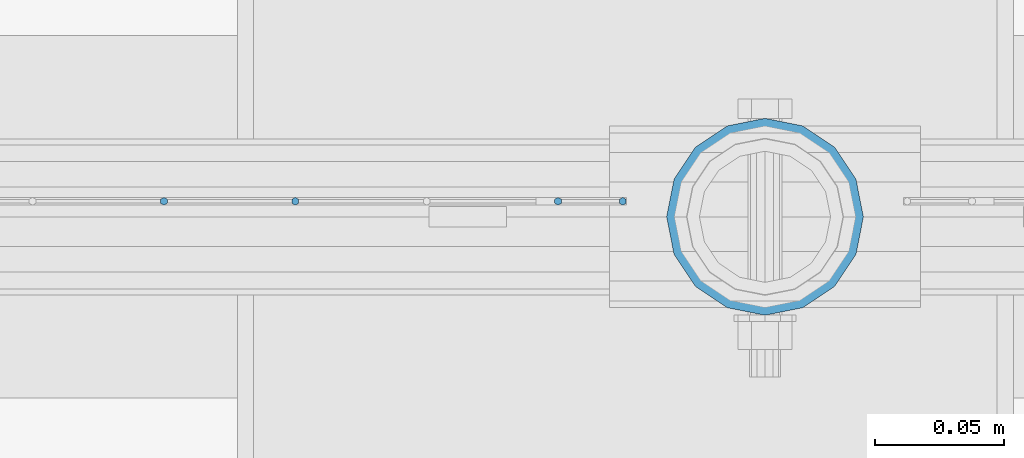
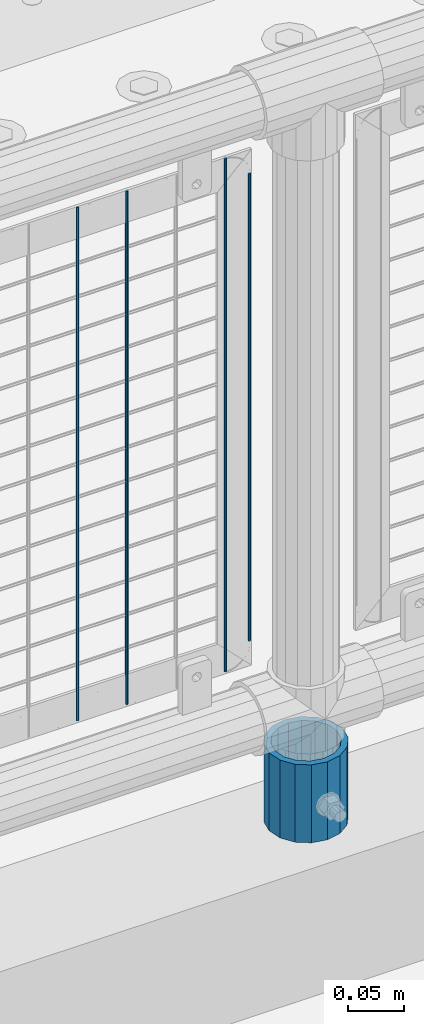
# One storey, part 66 of 242: 5 columns.
"""IFC2X3 building model written with IfcOpenShell, lengths in millimetres."""

from ifc_helpers import new_model, si_unit, frame, origin_with_axes, place, context, subcontext, project, spatial, faceted_brep, material, type_object, element, save


model = new_model("IFC2X3")

# Units and contexts
model_context = context("Model", 3, precision=1e-05, world=origin_with_axes())
body_context = subcontext(model_context, "Body", "Model", "MODEL_VIEW")
ifc_project = project(units=[si_unit("LENGTHUNIT", "METRE", prefix="MILLI"), si_unit("AREAUNIT", "SQUARE_METRE"), si_unit("VOLUMEUNIT", "CUBIC_METRE"), si_unit("MASSUNIT", "GRAM", prefix="KILO"), si_unit("TIMEUNIT", "SECOND"), si_unit("PLANEANGLEUNIT", "RADIAN"), si_unit("SOLIDANGLEUNIT", "STERADIAN"), si_unit("THERMODYNAMICTEMPERATUREUNIT", "DEGREE_CELSIUS"), si_unit("LUMINOUSINTENSITYUNIT", "LUMEN")], contexts=[model_context])

# Site, building, storey
site_placement = place(None, origin_with_axes())
site = spatial("IfcSite", under=ifc_project, at=site_placement, CompositionType="ELEMENT")
building_placement = place(site_placement, origin_with_axes())
building = spatial("IfcBuilding", under=site, at=building_placement, Name="Standard", CompositionType="ELEMENT")
storey_placement = place(building_placement, origin_with_axes())
storey = spatial("IfcBuildingStorey", under=building, at=storey_placement, Name="Undefined", CompositionType="ELEMENT", Elevation=0.0)

# Columns
ifc_material_1 = material(Name="Misc_Undefined")
column_type_1 = type_object("IfcColumnType", Name="D3", PredefinedType="NOTDEFINED")
for number, where, z_axis, x_axis in (
    (1, (-40377.589, -19329.5, 353.02), (-1.0, 0.0, 0.0), (0.0, 0.0, 1.0)),
    (2, (-40428.382, -19329.5, 353.02), (-1.0, 0.0, 0.0), (0.0, 0.0, 1.0)),
    (3, (-40276.003, -19329.5, 353.02), (-1.0, 0.0, 0.0), (0.0, 0.0, 1.0)),
):
    element("IfcColumn", number, at=place(storey_placement, frame(where, z_axis=z_axis, x_axis=x_axis)), inside=storey, type_object=column_type_1, material=ifc_material_1, ObjectType="D3", context=body_context, shape_type="Brep", body=[
        faceted_brep([(0.0, -1.50000000000364, 0.0), (-3.63797880709171e-12, -0.750000000003638, -1.29903810567669), (560.0, -0.75, -1.29903810567703), (560.0, -1.5, 0.0), (0.0, 0.749999999996362, -1.29903810567669), (560.0, 0.75, -1.29903810567703), (-3.63797880709171e-12, 1.49999999999636, 0.0), (560.0, 1.5, 0.0), (0.0, 0.749999999996362, 1.29903810567669), (560.0, 0.75, 1.29903810567703), (-3.63797880709171e-12, -0.750000000003638, 1.29903810567669), (560.0, -0.75, 1.29903810567703)], [[[0, 1, 2, 3]], [[1, 4, 5, 2]], [[4, 6, 7, 5]], [[6, 8, 9, 7]], [[8, 10, 11, 9]], [[10, 0, 3, 11]], [[5, 7, 9, 11, 3, 2]], [[10, 8, 6, 4, 1, 0]]]),
    ])
column_1_placement = place(storey_placement, frame((-40251.0, -19329.5, 378.02), z_axis=(-1.0, 0.0, 0.0), x_axis=(0.0, 0.0, 1.0)))
element("IfcColumn", 4, at=column_1_placement, inside=storey, type_object=column_type_1, material=ifc_material_1, ObjectType="D3", context=body_context, shape_type="Brep", body=[
    faceted_brep([(0.0, -1.50000000000364, 0.0), (-3.63797880709171e-12, -0.750000000003638, -1.29903810567669), (510.0, -0.75, -1.29903810567703), (510.0, -1.5, 0.0), (0.0, 0.749999999996362, -1.29903810567669), (510.0, 0.75, -1.29903810567703), (-3.63797880709171e-12, 1.49999999999636, 0.0), (510.0, 1.5, 0.0), (0.0, 0.749999999996362, 1.29903810567669), (510.0, 0.75, 1.29903810567703), (-3.63797880709171e-12, -0.750000000003638, 1.29903810567669), (510.0, -0.75, 1.29903810567703)], [[[0, 1, 2, 3]], [[1, 4, 5, 2]], [[4, 6, 7, 5]], [[6, 8, 9, 7]], [[8, 10, 11, 9]], [[10, 0, 3, 11]], [[5, 7, 9, 11, 3, 2]], [[10, 8, 6, 4, 1, 0]]]),
])
ifc_material_2 = material()
column_type_2 = type_object("IfcColumnType", PredefinedType="NOTDEFINED")
column_2_placement = place(storey_placement, frame((-40196.0, -19335.5, 168.02), z_axis=(0.0, 1.0, 0.0), x_axis=(0.0, 0.0, 1.0)))
element("IfcColumn", 5, at=column_2_placement, inside=storey, type_object=column_type_2, material=ifc_material_2, context=body_context, shape_type="Brep", body=[
    faceted_brep([(0.0, -31.75, 0.0), (0.0, -29.3331751572332, 12.1501989775934), (85.0, -29.3331751572332, 12.1501989775934), (85.0, -31.75, 0.0), (0.0, -22.4506403026717, 22.4506403026717), (85.0, -22.4506403026717, 22.4506403026717), (0.0, -12.1501989775934, 29.3331751572332), (85.0, -12.1501989775934, 29.3331751572332), (0.0, 0.0, 31.75), (85.0, 0.0, 31.75), (0.0, 12.1501989775934, 29.3331751572332), (85.0, 12.1501989775934, 29.3331751572332), (0.0, 22.4506403026717, 22.4506403026717), (85.0, 22.4506403026717, 22.4506403026717), (0.0, 29.3331751572332, 12.1501989775934), (85.0, 29.3331751572332, 12.1501989775934), (0.0, 31.75, 0.0), (85.0, 31.75, 0.0), (0.0, 29.3331751572332, -12.1501989775934), (85.0, 29.3331751572332, -12.1501989775934), (0.0, 22.4506403026717, -22.4506403026717), (85.0, 22.4506403026717, -22.4506403026717), (0.0, 12.1501989775934, -29.3331751572332), (85.0, 12.1501989775934, -29.3331751572332), (0.0, 0.0, -31.75), (85.0, 0.0, -31.75), (0.0, -12.1501989775934, -29.3331751572332), (85.0, -12.1501989775934, -29.3331751572332), (0.0, -22.4506403026717, -22.4506403026717), (85.0, -22.4506403026717, -22.4506403026717), (0.0, -29.3331751572332, -12.1501989775934), (85.0, -29.3331751572332, -12.1501989775934), (0.0, -38.0499999999993, 0.0), (0.0, -35.1536162120537, -14.5611046014928), (85.0, -35.1536162120537, -14.5611046014928), (85.0, -38.0499999999993, 0.0), (0.0, -26.9054130241493, -26.9054130241493), (85.0, -26.9054130241493, -26.9054130241493), (0.0, -14.5611046014928, -35.1536162120537), (85.0, -14.5611046014928, -35.1536162120537), (0.0, 0.0, -38.0499999999993), (85.0, 0.0, -38.0499999999993), (0.0, 14.5611046014928, -35.1536162120537), (85.0, 14.5611046014928, -35.1536162120537), (0.0, 26.9054130241493, -26.9054130241493), (85.0, 26.9054130241493, -26.9054130241493), (0.0, 35.1536162120537, -14.5611046014928), (85.0, 35.1536162120537, -14.5611046014928), (0.0, 38.0499999999993, 0.0), (85.0, 38.0499999999993, 0.0), (0.0, 35.1536162120537, 14.5611046014928), (85.0, 35.1536162120537, 14.5611046014928), (0.0, 26.9054130241493, 26.9054130241493), (85.0, 26.9054130241493, 26.9054130241493), (0.0, 14.5611046014928, 35.1536162120537), (85.0, 14.5611046014928, 35.1536162120537), (0.0, 0.0, 38.0499999999993), (85.0, 0.0, 38.0499999999993), (0.0, -14.5611046014928, 35.1536162120537), (85.0, -14.5611046014928, 35.1536162120537), (0.0, -26.9054130241493, 26.9054130241493), (85.0, -26.9054130241493, 26.9054130241493), (0.0, -35.1536162120537, 14.5611046014928), (85.0, -35.1536162120537, 14.5611046014928)], [[[0, 1, 2, 3]], [[1, 4, 5, 2]], [[4, 6, 7, 5]], [[6, 8, 9, 7]], [[8, 10, 11, 9]], [[10, 12, 13, 11]], [[12, 14, 15, 13]], [[14, 16, 17, 15]], [[16, 18, 19, 17]], [[18, 20, 21, 19]], [[20, 22, 23, 21]], [[22, 24, 25, 23]], [[24, 26, 27, 25]], [[26, 28, 29, 27]], [[28, 30, 31, 29]], [[30, 0, 3, 31]], [[32, 33, 34, 35]], [[33, 36, 37, 34]], [[36, 38, 39, 37]], [[38, 40, 41, 39]], [[40, 42, 43, 41]], [[42, 44, 45, 43]], [[44, 46, 47, 45]], [[46, 48, 49, 47]], [[48, 50, 51, 49]], [[50, 52, 53, 51]], [[52, 54, 55, 53]], [[54, 56, 57, 55]], [[56, 58, 59, 57]], [[58, 60, 61, 59]], [[60, 62, 63, 61]], [[62, 32, 35, 63]], [[37, 39, 41, 43, 45, 47, 49, 51, 53, 55, 57, 59, 61, 63, 35, 34], [5, 7, 9, 11, 13, 15, 17, 19, 21, 23, 25, 27, 29, 31, 3, 2]], [[62, 60, 58, 56, 54, 52, 50, 48, 46, 44, 42, 40, 38, 36, 33, 32], [30, 28, 26, 24, 22, 20, 18, 16, 14, 12, 10, 8, 6, 4, 1, 0]]]),
])

save(model, "model.ifc")
